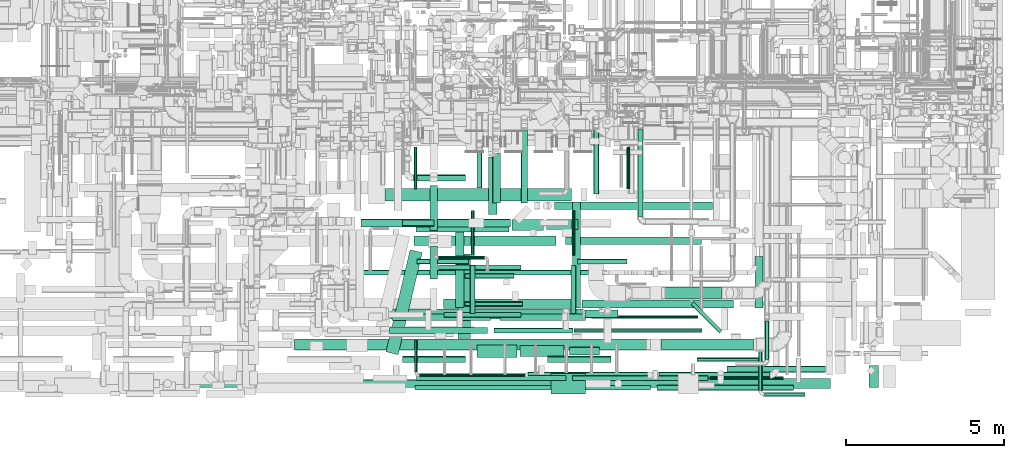
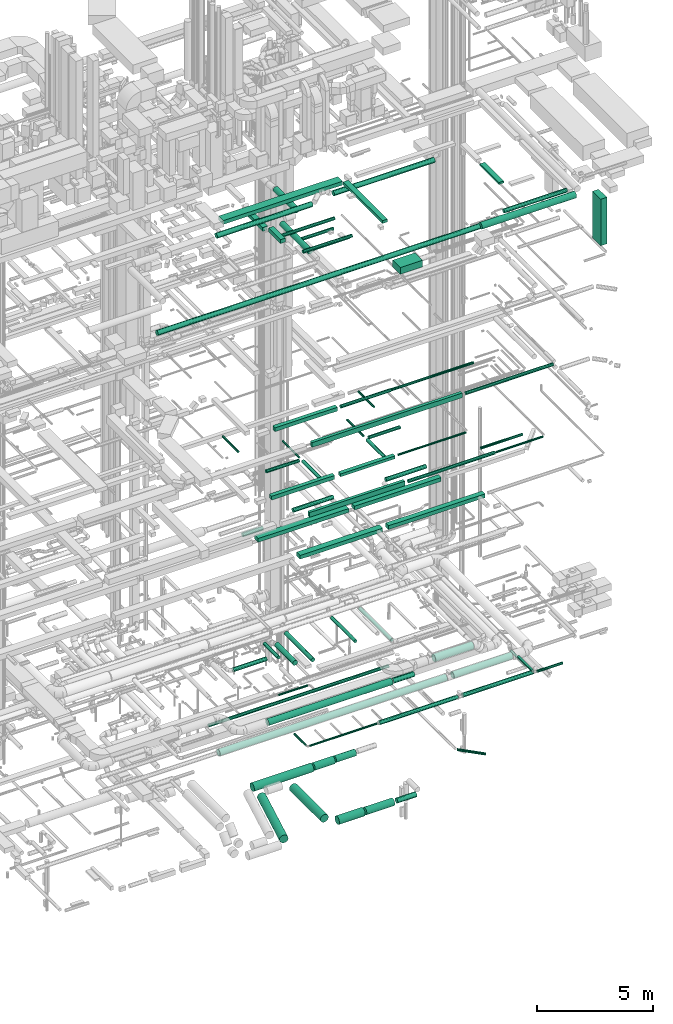
# One storey, part 49 of 337: 74 flow segments.
"""IFC2X3 building model written with IfcOpenShell, lengths in millimetres."""

from ifc_helpers import new_model, entity, si_unit, converted_unit, derived_unit, direction, frame, origin, origin_2d_with_axis, place, context, subcontext, project, spatial, polyline, rectangle, circle, outline, extrude, type_object, element, save


model = new_model("IFC2X3")

# Units and contexts
model_context = context("Model", 3, precision=0.01, world=origin(), true_north=direction((6.12303176911189e-17, 1.0)))
body_context = subcontext(model_context, "Body", "Model", "MODEL_VIEW")
ifc_project = project(units=[si_unit("LENGTHUNIT", "METRE", prefix="MILLI"), si_unit("AREAUNIT", "SQUARE_METRE"), si_unit("VOLUMEUNIT", "CUBIC_METRE"), converted_unit("PLANEANGLEUNIT", "DEGREE", entity("IfcRatioMeasure", 0.0174532925199433), si_unit("PLANEANGLEUNIT", "RADIAN"), dimensions=[0, 0, 0, 0, 0, 0, 0]), si_unit("MASSUNIT", "GRAM", prefix="KILO"), derived_unit("MASSDENSITYUNIT", [(si_unit("MASSUNIT", "GRAM", prefix="KILO"), 1), (si_unit("LENGTHUNIT", "METRE"), -3)]), derived_unit("MOMENTOFINERTIAUNIT", [(si_unit("LENGTHUNIT", "METRE"), 4)]), si_unit("TIMEUNIT", "SECOND"), si_unit("FREQUENCYUNIT", "HERTZ"), si_unit("THERMODYNAMICTEMPERATUREUNIT", "DEGREE_CELSIUS"), derived_unit("THERMALTRANSMITTANCEUNIT", [(si_unit("MASSUNIT", "GRAM", prefix="KILO"), 1), (si_unit("THERMODYNAMICTEMPERATUREUNIT", "KELVIN"), -1), (si_unit("TIMEUNIT", "SECOND"), -3)]), derived_unit("VOLUMETRICFLOWRATEUNIT", [(si_unit("LENGTHUNIT", "METRE"), 3), (si_unit("TIMEUNIT", "SECOND"), -1)]), derived_unit("MASSFLOWRATEUNIT", [(si_unit("MASSUNIT", "GRAM", prefix="KILO"), 1), (si_unit("TIMEUNIT", "SECOND"), -1)]), derived_unit("ROTATIONALFREQUENCYUNIT", [(si_unit("TIMEUNIT", "SECOND"), -1)]), si_unit("ELECTRICCURRENTUNIT", "AMPERE"), si_unit("ELECTRICVOLTAGEUNIT", "VOLT"), si_unit("POWERUNIT", "WATT"), si_unit("FORCEUNIT", "NEWTON", prefix="KILO"), si_unit("ILLUMINANCEUNIT", "LUX"), si_unit("LUMINOUSFLUXUNIT", "LUMEN"), si_unit("LUMINOUSINTENSITYUNIT", "CANDELA"), derived_unit("USERDEFINED", [(si_unit("MASSUNIT", "GRAM", prefix="KILO"), -1), (si_unit("LENGTHUNIT", "METRE"), -2), (si_unit("TIMEUNIT", "SECOND"), 3), (si_unit("LUMINOUSFLUXUNIT", "LUMEN"), 1)]), derived_unit("LINEARVELOCITYUNIT", [(si_unit("LENGTHUNIT", "METRE"), 1), (si_unit("TIMEUNIT", "SECOND"), -1)]), si_unit("PRESSUREUNIT", "PASCAL"), derived_unit("USERDEFINED", [(si_unit("LENGTHUNIT", "METRE"), -2), (si_unit("MASSUNIT", "GRAM", prefix="KILO"), 1), (si_unit("TIMEUNIT", "SECOND"), -2)]), derived_unit("LINEARFORCEUNIT", [(si_unit("MASSUNIT", "GRAM", prefix="KILO"), 1), (si_unit("LENGTHUNIT", "METRE"), 1), (si_unit("TIMEUNIT", "SECOND"), -2), (si_unit("LENGTHUNIT", "METRE"), -1)]), derived_unit("PLANARFORCEUNIT", [(si_unit("MASSUNIT", "GRAM", prefix="KILO"), 1), (si_unit("LENGTHUNIT", "METRE"), 1), (si_unit("TIMEUNIT", "SECOND"), -2), (si_unit("LENGTHUNIT", "METRE"), -2)])], contexts=[model_context])

# Site, building, storey
site_placement = place(None, origin())
site = spatial("IfcSite", under=ifc_project, at=site_placement, CompositionType="ELEMENT")
building_placement = place(site_placement, origin())
building = spatial("IfcBuilding", under=site, at=building_placement, CompositionType="ELEMENT")
storey_placement = place(building_placement, origin())
storey = spatial("IfcBuildingStorey", under=building, at=storey_placement, CompositionType="ELEMENT", Elevation=0.0)

# Flow segments
duct_segment_type_1 = type_object("IfcDuctSegmentType", PredefinedType="NOTDEFINED")
flow_segment_1_placement = place(storey_placement, frame((54557.3, 4970.54, 11300.0)))
element("IfcFlowSegment", 1, at=flow_segment_1_placement, inside=storey, type_object=duct_segment_type_1, context=body_context, shape_type="SweptSolid", body=[
    extrude(rectangle(XDim=4500.00000000001, YDim=300.0, at=origin_2d_with_axis()), frame((2250.0, 150.0, 0.0)), (0.0, 0.0, 1.0), 199.999999999998),
])
flow_segment_2_placement = place(storey_placement, frame((59357.3, 4995.54, 11300.0)))
element("IfcFlowSegment", 2, at=flow_segment_2_placement, inside=storey, type_object=duct_segment_type_1, context=body_context, shape_type="SweptSolid", body=[
    extrude(rectangle(XDim=4300.00000000001, YDim=249.999999999999, at=origin_2d_with_axis()), frame((2150.0, 125.0, 0.0)), (0.0, 0.0, 1.0), 200.000000000002),
])
flow_segment_3_placement = place(storey_placement, frame((55481.92, 2972.88, 11300.0)))
element("IfcFlowSegment", 3, at=flow_segment_3_placement, inside=storey, type_object=duct_segment_type_1, context=body_context, shape_type="SweptSolid", body=[
    extrude(rectangle(XDim=4100.00000000001, YDim=300.0, at=origin_2d_with_axis()), frame((2050.0, 150.0, 0.0)), (0.0, 0.0, 1.0), 199.999999999998),
])
flow_segment_4_placement = place(storey_placement, frame((59881.92, 2997.88, 11300.0)))
element("IfcFlowSegment", 4, at=flow_segment_4_placement, inside=storey, type_object=duct_segment_type_1, context=body_context, shape_type="SweptSolid", body=[
    extrude(rectangle(XDim=4799.99999999995, YDim=250.0, at=origin_2d_with_axis()), frame((2400.0, 125.0, 0.0)), (0.0, 0.0, 1.0), 200.000000000002),
])
flow_segment_5_placement = place(storey_placement, frame((53785.22, 2177.06, 19075.0)))
element("IfcFlowSegment", 5, at=flow_segment_5_placement, inside=storey, type_object=duct_segment_type_1, context=body_context, shape_type="SweptSolid", body=[
    extrude(rectangle(XDim=3099.99999999995, YDim=200.0, at=origin_2d_with_axis()), frame((1550.0, 100.0, 0.0)), (0.0, 0.0, 1.0), 200.000000000002),
])
flow_segment_6_placement = place(storey_placement, frame((54587.23, 388.31, 19050.0)))
element("IfcFlowSegment", 6, at=flow_segment_6_placement, inside=storey, type_object=duct_segment_type_1, context=body_context, shape_type="SweptSolid", body=[
    extrude(rectangle(XDim=7459.99999999995, YDim=150.0, at=origin_2d_with_axis()), frame((3730.0, 75.0, 0.0)), (0.0, 0.0, 1.0), 249.999999999999),
])
flow_segment_7_placement = place(storey_placement, frame((53861.01, 2600.44, 15200.0)))
element("IfcFlowSegment", 7, at=flow_segment_7_placement, inside=storey, type_object=duct_segment_type_1, context=body_context, shape_type="SweptSolid", body=[
    extrude(rectangle(XDim=3120.00000000006, YDim=200.0, at=origin_2d_with_axis()), frame((1560.0, 100.0, 0.0)), (0.0, 0.0, 1.0), 199.999999999998),
])
flow_segment_8_placement = place(storey_placement, frame((57281.01, 2600.44, 15225.0)))
element("IfcFlowSegment", 8, at=flow_segment_8_placement, inside=storey, type_object=duct_segment_type_1, context=body_context, shape_type="SweptSolid", body=[
    extrude(rectangle(XDim=2699.99999999995, YDim=200.0, at=origin_2d_with_axis()), frame((1350.0, 100.0, 0.0)), (0.0, 0.0, 1.0), 150.000000000001),
])
flow_segment_9_placement = place(storey_placement, frame((54639.29, 695.66, 15175.0)))
element("IfcFlowSegment", 9, at=flow_segment_9_placement, inside=storey, type_object=duct_segment_type_1, context=body_context, shape_type="SweptSolid", body=[
    extrude(rectangle(XDim=4729.15029264255, YDim=150.0, at=origin_2d_with_axis()), frame((2364.58, 75.0, 0.0)), (0.0, 0.0, 1.0), 249.999999999999),
])
flow_segment_10_placement = place(storey_placement, frame((53635.82, 6380.41, 27450.0)))
element("IfcFlowSegment", 10, at=flow_segment_10_placement, inside=storey, type_object=duct_segment_type_1, context=body_context, shape_type="SweptSolid", body=[
    extrude(rectangle(XDim=5913.75000000002, YDim=400.0, at=origin_2d_with_axis()), frame((2956.88, 200.0, 0.0), z_axis=(0.0, 0.0, 1.0), x_axis=(-1.0, 0.0, 0.0)), (0.0, 0.0, 1.0), 199.999999999998),
])
flow_segment_11_placement = place(storey_placement, frame((59574.57, 2987.91, 27475.0)))
element("IfcFlowSegment", 11, at=flow_segment_11_placement, inside=storey, type_object=duct_segment_type_1, context=body_context, shape_type="SweptSolid", body=[
    extrude(rectangle(XDim=3367.49999999998, YDim=250.000000000004, at=origin_2d_with_axis()), frame((125.0, 1683.75, 0.0), z_axis=(0.0, 0.0, 1.0), x_axis=(0.0, 1.0, 0.0)), (0.0, 0.0, 1.0), 150.000000000001),
])
flow_segment_12_placement = place(storey_placement, frame((65354.57, 2987.91, 27500.0)))
element("IfcFlowSegment", 12, at=flow_segment_12_placement, inside=storey, type_object=duct_segment_type_1, context=body_context, shape_type="SweptSolid", body=[
    extrude(rectangle(XDim=1636.24999999996, YDim=250.000000000004, at=origin_2d_with_axis()), frame((125.0, 818.12, 0.0), z_axis=(0.0, 0.0, 1.0), x_axis=(0.0, -1.0, 0.0)), (0.0, 0.0, 1.0), 100.000000000003),
])
flow_segment_13_placement = place(storey_placement, frame((68968.15, 473.12, 24545.0)))
element("IfcFlowSegment", 13, at=flow_segment_13_placement, inside=storey, type_object=duct_segment_type_1, context=body_context, shape_type="SweptSolid", body=[
    extrude(rectangle(XDim=700.0, YDim=300.000000000001, at=origin_2d_with_axis()), frame((150.0, 350.0, 0.0), z_axis=(0.0, 0.0, 1.0), x_axis=(0.0, -1.0, 0.0)), (0.0, 0.0, 1.0), 2440.00000000001),
])
flow_segment_14_placement = place(storey_placement, frame((55054.59, 5448.41, 27150.0)))
element("IfcFlowSegment", 14, at=flow_segment_14_placement, inside=storey, type_object=duct_segment_type_1, context=body_context, shape_type="SweptSolid", body=[
    extrude(rectangle(XDim=1430.81282899736, YDim=250.000000000004, at=origin_2d_with_axis()), frame((125.0, 715.41, 0.0), z_axis=(0.0, 0.0, 1.0), x_axis=(0.0, -1.0, 0.0)), (0.0, 0.0, 1.0), 199.999999999998),
])
flow_segment_15_placement = place(storey_placement, frame((55054.59, 3912.24, 27450.0)))
element("IfcFlowSegment", 15, at=flow_segment_15_placement, inside=storey, type_object=duct_segment_type_1, context=body_context, shape_type="SweptSolid", body=[
    extrude(rectangle(XDim=1029.05982822021, YDim=250.000000000004, at=origin_2d_with_axis()), frame((125.0, 514.53, 0.0), z_axis=(0.0, 0.0, 1.0), x_axis=(0.0, 1.0, 0.0)), (0.0, 0.0, 1.0), 199.999999999998),
])
flow_segment_16_placement = place(storey_placement, frame((58894.8, 268.17, 26700.0)))
element("IfcFlowSegment", 16, at=flow_segment_16_placement, inside=storey, type_object=duct_segment_type_1, context=body_context, shape_type="SweptSolid", body=[
    extrude(rectangle(XDim=1100.0, YDim=650.0, at=origin_2d_with_axis()), frame((550.0, 325.0, 0.0)), (0.0, 0.0, 1.0), 349.999999999998),
])
duct_segment_type_2 = type_object("IfcDuctSegmentType", PredefinedType="NOTDEFINED")
flow_segment_17_placement = place(storey_placement, frame((54616.92, 5397.13, -2151.6)))
element("IfcFlowSegment", 17, at=flow_segment_17_placement, inside=storey, type_object=duct_segment_type_2, context=body_context, shape_type="SweptSolid", body=[
    extrude(circle(Radius=200.0, at=origin_2d_with_axis()), frame((0.0, 201.6, 201.6), z_axis=(1.0, 0.0, 0.0), x_axis=(0.0, -1.0, 0.0)), (0.0, 0.0, 1.0), 2951.06360611809),
])
flow_segment_18_placement = place(storey_placement, frame((57659.98, 5441.63, -2129.1)))
element("IfcFlowSegment", 18, at=flow_segment_18_placement, inside=storey, type_object=duct_segment_type_2, context=body_context, shape_type="SweptSolid", body=[
    extrude(circle(Radius=177.5, at=origin_2d_with_axis()), frame((0.0, 179.1, 179.1), z_axis=(1.0, 0.0, 0.0), x_axis=(0.0, -1.0, 0.0)), (0.0, 0.0, 1.0), 999.633099706871),
])
flow_segment_19_placement = place(storey_placement, frame((58744.62, 5482.13, -2109.1)))
element("IfcFlowSegment", 19, at=flow_segment_19_placement, inside=storey, type_object=duct_segment_type_2, context=body_context, shape_type="SweptSolid", body=[
    extrude(circle(Radius=157.5, at=origin_2d_with_axis()), frame((0.0, 159.1, 159.1), z_axis=(1.0, 0.0, 0.0), x_axis=(0.0, -1.0, 0.0)), (0.0, 0.0, 1.0), 999.769934937476),
])
flow_segment_20_placement = place(storey_placement, frame((53661.77, 1508.85, -2151.6)))
element("IfcFlowSegment", 20, at=flow_segment_20_placement, inside=storey, type_object=duct_segment_type_2, context=body_context, shape_type="SweptSolid", body=[
    extrude(circle(Radius=200.0, at=origin_2d_with_axis()), frame((196.21, 47.69, 201.6), z_axis=(0.230466228592691, 0.973080324268383, 0.0), x_axis=(-0.973080324268383, 0.230466228592691, 0.0)), (0.0, 0.0, 1.0), 3323.43288947381),
])
flow_segment_21_placement = place(storey_placement, frame((55942.39, 2026.52, -2151.6)))
element("IfcFlowSegment", 21, at=flow_segment_21_placement, inside=storey, type_object=duct_segment_type_2, context=body_context, shape_type="SweptSolid", body=[
    extrude(circle(Radius=200.0, at=origin_2d_with_axis()), frame((201.6, 0.0, 201.6), z_axis=(0.0, 1.0, 0.0), x_axis=(-1.0, 0.0, 0.0)), (0.0, 0.0, 1.0), 2671.80245293195),
])
flow_segment_22_placement = place(storey_placement, frame((59484.61, 1499.92, -2076.6)))
element("IfcFlowSegment", 22, at=flow_segment_22_placement, inside=storey, type_object=duct_segment_type_2, context=body_context, shape_type="SweptSolid", body=[
    extrude(circle(Radius=125.0, at=origin_2d_with_axis()), frame((0.0, 126.6, 126.6), z_axis=(1.0, 0.0, 0.0), x_axis=(0.0, -1.0, 0.0)), (0.0, 0.0, 1.0), 954.521669775234),
])
flow_segment_23_placement = place(storey_placement, frame((56543.98, 1424.92, -2151.6)))
element("IfcFlowSegment", 23, at=flow_segment_23_placement, inside=storey, type_object=duct_segment_type_2, context=body_context, shape_type="SweptSolid", body=[
    extrude(circle(Radius=200.0, at=origin_2d_with_axis()), frame((0.0, 201.6, 201.6), z_axis=(1.0, 0.0, 0.0), x_axis=(0.0, -1.0, 0.0)), (0.0, 0.0, 1.0), 1280.36323550003),
])
flow_segment_24_placement = place(storey_placement, frame((57916.35, 1447.42, -2129.1)))
element("IfcFlowSegment", 24, at=flow_segment_24_placement, inside=storey, type_object=duct_segment_type_2, context=body_context, shape_type="SweptSolid", body=[
    extrude(circle(Radius=177.5, at=origin_2d_with_axis()), frame((0.0, 179.1, 179.1), z_axis=(1.0, 0.0, 0.0), x_axis=(0.0, -1.0, 0.0)), (0.0, 0.0, 1.0), 1394.26236472474),
])
flow_segment_25_placement = place(storey_placement, frame((63328.93, 2191.65, -1614.1)))
element("IfcFlowSegment", 25, at=flow_segment_25_placement, inside=storey, type_object=duct_segment_type_2, context=body_context, shape_type="SweptSolid", body=[
    extrude(circle(Radius=62.5, at=origin_2d_with_axis()), frame((946.44, 45.79, 64.1), z_axis=(-0.707106781186597, 0.707106781186498, 0.0), x_axis=(-0.707106781186498, -0.707106781186597, 0.0)), (0.0, 0.0, 1.0), 1273.71806347082),
])
flow_segment_26_placement = place(storey_placement, frame((54181.92, 5578.95, 11298.4)))
element("IfcFlowSegment", 26, at=flow_segment_26_placement, inside=storey, type_object=duct_segment_type_2, context=body_context, shape_type="SweptSolid", body=[
    extrude(circle(Radius=100.0, at=origin_2d_with_axis()), frame((0.0, 101.6, 101.6), z_axis=(1.0, 0.0, 0.0), x_axis=(0.0, -1.0, 0.0)), (0.0, 0.0, 1.0), 999.99999999992),
])
flow_segment_27_placement = place(storey_placement, frame((53750.84, 2644.65, 3290.9)))
element("IfcFlowSegment", 27, at=flow_segment_27_placement, inside=storey, type_object=duct_segment_type_2, context=body_context, shape_type="SweptSolid", body=[
    extrude(circle(Radius=157.5, at=origin_2d_with_axis()), frame((0.0, 159.1, 159.1), z_axis=(1.0, 0.0, 0.0), x_axis=(0.0, -1.0, 0.0)), (0.0, 0.0, 1.0), 6152.38970540996),
])
flow_segment_28_placement = place(storey_placement, frame((59968.23, 2677.15, 3323.4)))
element("IfcFlowSegment", 28, at=flow_segment_28_placement, inside=storey, type_object=duct_segment_type_2, context=body_context, shape_type="SweptSolid", body=[
    extrude(circle(Radius=125.0, at=origin_2d_with_axis()), frame((0.0, 126.6, 126.6), z_axis=(1.0, 0.0, 0.0), x_axis=(0.0, -1.0, 0.0)), (0.0, 0.0, 1.0), 1044.99999999996),
])
flow_segment_29_placement = place(storey_placement, frame((61645.81, 5891.17, 3018.4)))
element("IfcFlowSegment", 29, at=flow_segment_29_placement, inside=storey, type_object=duct_segment_type_2, context=body_context, shape_type="SweptSolid", body=[
    extrude(outline(polyline([(-10.44, -79.32), (10.44, -79.32), (30.61, -73.91), (48.7, -63.47), (63.47, -48.7), (73.91, -30.61), (79.32, -10.44), (79.32, 10.44), (73.91, 30.61), (63.47, 48.7), (48.7, 63.47), (30.61, 73.91), (10.44, 79.32), (-10.44, 79.32), (-30.61, 73.91), (-48.7, 63.47), (-63.47, 48.7), (-73.91, 30.61), (-79.32, 10.44), (-79.32, -10.44), (-73.91, -30.61), (-63.47, -48.7), (-48.7, -63.47), (-30.61, -73.91), (-10.44, -79.32)])), frame((81.6, 0.0, 81.6), z_axis=(8.3440502931814e-09, 1.0, 0.0), x_axis=(0.130526192220055, -1.08913121497131e-09, 0.99144486137381)), (0.0, 0.0, 1.0), 2751.21031061176),
])
flow_segment_30_placement = place(storey_placement, frame((65670.58, 1352.18, 3075.9)))
element("IfcFlowSegment", 30, at=flow_segment_30_placement, inside=storey, type_object=duct_segment_type_2, context=body_context, shape_type="SweptSolid", body=[
    extrude(circle(Radius=62.5, at=origin_2d_with_axis()), frame((64.1, 0.0, 64.1), z_axis=(0.0, 1.0, 0.0), x_axis=(-1.0, 0.0, 0.0)), (0.0, 0.0, 1.0), 1230.00000000002),
])
flow_segment_31_placement = place(storey_placement, frame((62247.23, 381.72, 19093.4)))
element("IfcFlowSegment", 31, at=flow_segment_31_placement, inside=storey, type_object=duct_segment_type_2, context=body_context, shape_type="SweptSolid", body=[
    extrude(circle(Radius=80.0, at=origin_2d_with_axis()), frame((0.0, 81.6, 81.6), z_axis=(1.0, 0.0, 0.0), x_axis=(0.0, -1.0, 0.0)), (0.0, 0.0, 1.0), 4336.87499999998),
])
flow_segment_32_placement = place(storey_placement, frame((56332.36, 2820.44, 15218.4)))
element("IfcFlowSegment", 32, at=flow_segment_32_placement, inside=storey, type_object=duct_segment_type_2, context=body_context, shape_type="SweptSolid", body=[
    extrude(circle(Radius=80.0, at=origin_2d_with_axis()), frame((81.6, 0.0, 81.6), z_axis=(-3.39017242221054e-07, 1.0, 0.0), x_axis=(-1.0, -3.39017242221054e-07, 0.0)), (0.0, 0.0, 1.0), 1511.64807287868),
])
flow_segment_33_placement = place(storey_placement, frame((56362.36, 4652.09, 15248.4)))
element("IfcFlowSegment", 33, at=flow_segment_33_placement, inside=storey, type_object=duct_segment_type_2, context=body_context, shape_type="SweptSolid", body=[
    extrude(circle(Radius=50.0, at=origin_2d_with_axis()), frame((51.6, 0.0, 51.6), z_axis=(0.0, 1.0, 0.0), x_axis=(1.0, 0.0, 0.0)), (0.0, 0.0, 1.0), 1420.0),
])
flow_segment_34_placement = place(storey_placement, frame((54643.95, 4380.5, 15218.4)))
element("IfcFlowSegment", 34, at=flow_segment_34_placement, inside=storey, type_object=duct_segment_type_2, context=body_context, shape_type="SweptSolid", body=[
    extrude(circle(Radius=80.0, at=origin_2d_with_axis()), frame((0.0, 81.6, 81.6), z_axis=(1.0, 0.0, 0.0), x_axis=(0.0, 1.0, 0.0)), (0.0, 0.0, 1.0), 1639.9995451582),
])
flow_segment_35_placement = place(storey_placement, frame((59526.85, 2820.44, 15218.4)))
element("IfcFlowSegment", 35, at=flow_segment_35_placement, inside=storey, type_object=duct_segment_type_2, context=body_context, shape_type="SweptSolid", body=[
    extrude(circle(Radius=80.0, at=origin_2d_with_axis()), frame((81.6, 0.0, 81.6), z_axis=(-3.39017242221043e-07, 1.0, 0.0), x_axis=(-1.0, -3.39017242221043e-07, 0.0)), (0.0, 0.0, 1.0), 1511.64807287874),
])
flow_segment_36_placement = place(storey_placement, frame((59556.85, 4652.09, 15248.4)))
element("IfcFlowSegment", 36, at=flow_segment_36_placement, inside=storey, type_object=duct_segment_type_2, context=body_context, shape_type="SweptSolid", body=[
    extrude(circle(Radius=50.0, at=origin_2d_with_axis()), frame((51.6, 0.0, 51.6), z_axis=(0.0, 1.0, 0.0), x_axis=(1.0, 0.0, 0.0)), (0.0, 0.0, 1.0), 1420.0),
])
flow_segment_37_placement = place(storey_placement, frame((59738.45, 4380.5, 15218.4)))
element("IfcFlowSegment", 37, at=flow_segment_37_placement, inside=storey, type_object=duct_segment_type_2, context=body_context, shape_type="SweptSolid", body=[
    extrude(circle(Radius=80.0, at=origin_2d_with_axis()), frame((0.0, 81.6, 81.6), z_axis=(1.0, 0.0, 0.0), x_axis=(0.0, -1.0, 0.0)), (0.0, 0.0, 1.0), 1560.0),
])
flow_segment_38_placement = place(storey_placement, frame((60181.01, 2648.85, 15248.4)))
element("IfcFlowSegment", 38, at=flow_segment_38_placement, inside=storey, type_object=duct_segment_type_2, context=body_context, shape_type="SweptSolid", body=[
    extrude(circle(Radius=50.0, at=origin_2d_with_axis()), frame((0.0, 51.6, 51.6), z_axis=(1.0, 0.0, 0.0), x_axis=(0.0, 1.0, 0.0)), (0.0, 0.0, 1.0), 3375.00000000001),
])
flow_segment_39_placement = place(storey_placement, frame((54190.19, 1260.8, 15198.4)))
element("IfcFlowSegment", 39, at=flow_segment_39_placement, inside=storey, type_object=duct_segment_type_2, context=body_context, shape_type="SweptSolid", body=[
    extrude(circle(Radius=100.0, at=origin_2d_with_axis()), frame((0.0, 101.6, 101.6), z_axis=(1.0, 0.0, 0.0), x_axis=(0.0, -1.0, 0.0)), (0.0, 0.0, 1.0), 2000.00000000001),
])
flow_segment_40_placement = place(storey_placement, frame((61288.96, 6759.63, 14898.4)))
element("IfcFlowSegment", 40, at=flow_segment_40_placement, inside=storey, type_object=duct_segment_type_2, context=body_context, shape_type="SweptSolid", body=[
    extrude(circle(Radius=50.0, at=origin_2d_with_axis()), frame((51.6, 0.0, 51.6), z_axis=(0.0, 1.0, 0.0), x_axis=(-1.0, 0.0, 0.0)), (0.0, 0.0, 1.0), 1340.00000000001),
])
flow_segment_41_placement = place(storey_placement, frame((54554.25, 6759.63, 14898.4)))
element("IfcFlowSegment", 41, at=flow_segment_41_placement, inside=storey, type_object=duct_segment_type_2, context=body_context, shape_type="SweptSolid", body=[
    extrude(circle(Radius=50.0, at=origin_2d_with_axis()), frame((51.6, 0.0, 51.6), z_axis=(0.0, 1.0, 0.0), x_axis=(-1.0, 0.0, 0.0)), (0.0, 0.0, 1.0), 1340.00000000008),
])
flow_segment_42_placement = place(storey_placement, frame((58790.19, 1260.8, 15198.4)))
element("IfcFlowSegment", 42, at=flow_segment_42_placement, inside=storey, type_object=duct_segment_type_2, context=body_context, shape_type="SweptSolid", body=[
    extrude(circle(Radius=100.0, at=origin_2d_with_axis()), frame((0.0, 101.6, 101.6), z_axis=(1.0, 0.0, 0.0), x_axis=(0.0, -1.0, 0.0)), (0.0, 0.0, 1.0), 2000.00000000001),
])
flow_segment_43_placement = place(storey_placement, frame((59568.45, 689.06, 15218.4)))
element("IfcFlowSegment", 43, at=flow_segment_43_placement, inside=storey, type_object=duct_segment_type_2, context=body_context, shape_type="SweptSolid", body=[
    extrude(circle(Radius=80.0, at=origin_2d_with_axis()), frame((0.0, 81.6, 81.6), z_axis=(1.0, 0.0, 0.0), x_axis=(0.0, -1.0, 0.0)), (0.0, 0.0, 1.0), 4300.0),
])
flow_segment_44_placement = place(storey_placement, frame((63515.19, 1298.3, 15235.9)))
element("IfcFlowSegment", 44, at=flow_segment_44_placement, inside=storey, type_object=duct_segment_type_2, context=body_context, shape_type="SweptSolid", body=[
    extrude(circle(Radius=62.5, at=origin_2d_with_axis()), frame((0.0, 64.1, 64.1), z_axis=(1.0, 0.0, 0.0), x_axis=(0.0, -1.0, 0.0)), (0.0, 0.0, 1.0), 2075.00000000007),
])
flow_segment_45_placement = place(storey_placement, frame((63928.45, 719.06, 15248.4)))
element("IfcFlowSegment", 45, at=flow_segment_45_placement, inside=storey, type_object=duct_segment_type_2, context=body_context, shape_type="SweptSolid", body=[
    extrude(circle(Radius=50.0, at=origin_2d_with_axis()), frame((0.0, 51.6, 51.6), z_axis=(1.0, 0.0, 0.0), x_axis=(0.0, -1.0, 0.0)), (0.0, 0.0, 1.0), 2340.00000000001),
])
flow_segment_46_placement = place(storey_placement, frame((64469.87, 948.29, 27498.4)))
element("IfcFlowSegment", 46, at=flow_segment_46_placement, inside=storey, type_object=duct_segment_type_2, context=body_context, shape_type="SweptSolid", body=[
    extrude(circle(Radius=100.0, at=origin_2d_with_axis()), frame((0.0, 101.6, 101.6), z_axis=(1.0, 0.0, 0.0), x_axis=(0.0, 1.0, 0.0)), (0.0, 0.0, 1.0), 3126.86241545841),
])
flow_segment_47_placement = place(storey_placement, frame((55504.59, 2694.37, 27468.4)))
element("IfcFlowSegment", 47, at=flow_segment_47_placement, inside=storey, type_object=duct_segment_type_2, context=body_context, shape_type="SweptSolid", body=[
    extrude(circle(Radius=80.0, at=origin_2d_with_axis()), frame((0.0, 81.6, 81.6), z_axis=(1.0, 0.0, 0.0), x_axis=(0.0, -1.0, 0.0)), (0.0, 0.0, 1.0), 2434.58382599763),
])
flow_segment_48_placement = place(storey_placement, frame((55324.59, 4195.65, 27468.4)))
element("IfcFlowSegment", 48, at=flow_segment_48_placement, inside=storey, type_object=duct_segment_type_2, context=body_context, shape_type="SweptSolid", body=[
    extrude(circle(Radius=80.0, at=origin_2d_with_axis()), frame((0.0, 81.6, 81.6), z_axis=(1.0, 0.0, 0.0), x_axis=(0.0, -1.0, 0.0)), (0.0, 0.0, 1.0), 2616.24999999989),
])
flow_segment_49_placement = place(storey_placement, frame((55863.34, 3003.11, 27118.4)))
element("IfcFlowSegment", 49, at=flow_segment_49_placement, inside=storey, type_object=duct_segment_type_2, context=body_context, shape_type="SweptSolid", body=[
    extrude(circle(Radius=140.0, at=origin_2d_with_axis()), frame((141.6, 0.0, 141.6), z_axis=(0.0, 1.0, 0.0), x_axis=(1.0, 0.0, 0.0)), (0.0, 0.0, 1.0), 2397.49999999999),
])
flow_segment_50_placement = place(storey_placement, frame((56164.62, 3916.72, 27168.4)))
element("IfcFlowSegment", 50, at=flow_segment_50_placement, inside=storey, type_object=duct_segment_type_2, context=body_context, shape_type="SweptSolid", body=[
    extrude(circle(Radius=80.0, at=origin_2d_with_axis()), frame((0.0, 81.6, 81.6), z_axis=(1.0, 0.0, 0.0), x_axis=(0.0, -1.0, 0.0)), (0.0, 0.0, 1.0), 1560.31470495926),
])
flow_segment_51_placement = place(storey_placement, frame((56164.62, 3032.64, 27168.4)))
element("IfcFlowSegment", 51, at=flow_segment_51_placement, inside=storey, type_object=duct_segment_type_2, context=body_context, shape_type="SweptSolid", body=[
    extrude(circle(Radius=80.0, at=origin_2d_with_axis()), frame((0.0, 81.6, 81.6), z_axis=(1.0, 0.0, 0.0), x_axis=(0.0, -1.0, 0.0)), (0.0, 0.0, 1.0), 1820.31470495927),
])
flow_segment_52_placement = place(storey_placement, frame((63062.74, 434.08, 27430.9)))
element("IfcFlowSegment", 52, at=flow_segment_52_placement, inside=storey, type_object=duct_segment_type_2, context=body_context, shape_type="SweptSolid", body=[
    extrude(circle(Radius=157.5, at=origin_2d_with_axis()), frame((0.0, 159.1, 159.1), z_axis=(1.0, 0.0, 0.0), x_axis=(0.0, 1.0, 0.0)), (0.0, 0.0, 1.0), 4685.00000000001),
])
flow_segment_53_placement = place(storey_placement, frame((46997.3, 466.58, 27463.4)))
element("IfcFlowSegment", 53, at=flow_segment_53_placement, inside=storey, type_object=duct_segment_type_2, context=body_context, shape_type="SweptSolid", body=[
    extrude(circle(Radius=125.0, at=origin_2d_with_axis()), frame((0.0, 126.6, 126.6), z_axis=(1.0, 0.0, 0.0), x_axis=(0.0, 1.0, 0.0)), (0.0, 0.0, 1.0), 16000.4434048333),
])
flow_segment_54_placement = place(storey_placement, frame((60247.19, 6607.6, 3018.4)))
element("IfcFlowSegment", 54, at=flow_segment_54_placement, inside=storey, type_object=duct_segment_type_2, context=body_context, shape_type="SweptSolid", body=[
    extrude(outline(polyline([(-10.44, -79.32), (10.44, -79.32), (30.61, -73.91), (48.7, -63.47), (63.47, -48.7), (73.91, -30.61), (79.32, -10.44), (79.32, 10.44), (73.91, 30.61), (63.47, 48.7), (48.7, 63.47), (30.61, 73.91), (10.44, 79.32), (-10.44, 79.32), (-30.61, 73.91), (-48.7, 63.47), (-63.47, 48.7), (-73.91, 30.61), (-79.32, 10.44), (-79.32, -10.44), (-73.91, -30.61), (-63.47, -48.7), (-48.7, -63.47), (-30.61, -73.91), (-10.44, -79.32)])), frame((81.6, 0.0, 81.6), z_axis=(0.0, 1.0, 0.0), x_axis=(0.130526192220055, 0.0, 0.99144486137381)), (0.0, 0.0, 1.0), 2033.72583002032),
])
flow_segment_55_placement = place(storey_placement, frame((59003.03, 6103.9, 27174.04)))
element("IfcFlowSegment", 55, at=flow_segment_55_placement, inside=storey, type_object=duct_segment_type_2, context=body_context, shape_type="SweptSolid", body=[
    extrude(circle(Radius=125.0, at=origin_2d_with_axis()), frame((0.0, 125.96, 125.96), z_axis=(1.0, 0.0, 0.0), x_axis=(0.0, 0.584613414413232, 0.811311996514351)), (0.0, 0.0, 1.0), 5003.41101318828),
])
flow_segment_56_placement = place(storey_placement, frame((52877.39, 5553.69, 27423.4)))
element("IfcFlowSegment", 56, at=flow_segment_56_placement, inside=storey, type_object=duct_segment_type_2, context=body_context, shape_type="SweptSolid", body=[
    extrude(circle(Radius=125.0, at=origin_2d_with_axis()), frame((0.0, 126.6, 126.6), z_axis=(1.0, 0.0, 0.0), x_axis=(0.0, 1.0, 0.0)), (0.0, 0.0, 1.0), 4741.44660940679),
])
flow_segment_57_placement = place(storey_placement, frame((57948.72, 6311.05, 2998.4)))
element("IfcFlowSegment", 57, at=flow_segment_57_placement, inside=storey, type_object=duct_segment_type_2, context=body_context, shape_type="SweptSolid", body=[
    extrude(circle(Radius=100.0, at=origin_2d_with_axis()), frame((101.6, 0.0, 101.6), z_axis=(0.0, 1.0, 0.0), x_axis=(-1.0, 0.0, 0.0)), (0.0, 0.0, 1.0), 2317.24508060277),
])
flow_segment_58_placement = place(storey_placement, frame((54531.91, 7011.47, 3218.4)))
element("IfcFlowSegment", 58, at=flow_segment_58_placement, inside=storey, type_object=duct_segment_type_2, context=body_context, shape_type="SweptSolid", body=[
    extrude(circle(Radius=100.0, at=origin_2d_with_axis()), frame((0.0, 101.6, 101.6), z_axis=(1.0, 0.0, 0.0), x_axis=(0.0, -1.0, 0.0)), (0.0, 0.0, 1.0), 1660.20000000001),
])
flow_segment_59_placement = place(storey_placement, frame((56541.69, 6788.91, 3348.4)))
element("IfcFlowSegment", 59, at=flow_segment_59_placement, inside=storey, type_object=duct_segment_type_2, context=body_context, shape_type="SweptSolid", body=[
    extrude(circle(Radius=80.0, at=origin_2d_with_axis()), frame((81.6, 0.0, 81.6), z_axis=(5.06496820018117e-08, 1.0, 0.0), x_axis=(1.0, -5.06496820018117e-08, 0.0)), (0.0, 0.0, 1.0), 1211.27416997973),
])
flow_segment_60_placement = place(storey_placement, frame((54721.73, 810.59, 2998.4)))
element("IfcFlowSegment", 60, at=flow_segment_60_placement, inside=storey, type_object=duct_segment_type_2, context=body_context, shape_type="SweptSolid", body=[
    extrude(circle(Radius=50.0, at=origin_2d_with_axis()), frame((0.0, 51.6, 51.6), z_axis=(1.0, 0.0, 0.0), x_axis=(0.0, -1.0, 0.0)), (0.0, 0.0, 1.0), 3350.77104855534),
])
flow_segment_61_placement = place(storey_placement, frame((50763.55, 1670.27, 3340.9)))
element("IfcFlowSegment", 61, at=flow_segment_61_placement, inside=storey, type_object=duct_segment_type_2, context=body_context, shape_type="SweptSolid", body=[
    extrude(circle(Radius=157.5, at=origin_2d_with_axis()), frame((0.0, 159.1, 159.1), z_axis=(1.0, 0.0, 0.0), x_axis=(0.0, 1.0, 0.0)), (0.0, 0.0, 1.0), 11283.9478056898),
])
flow_segment_62_placement = place(storey_placement, frame((65471.87, 379.37, 3435.9)))
element("IfcFlowSegment", 62, at=flow_segment_62_placement, inside=storey, type_object=duct_segment_type_2, context=body_context, shape_type="SweptSolid", body=[
    extrude(circle(Radius=62.5, at=origin_2d_with_axis()), frame((64.1, 0.0, 64.1), z_axis=(0.0, 1.0, 0.0), x_axis=(-1.0, 0.0, 0.0)), (0.0, 0.0, 1.0), 1230.0),
])
flow_segment_63_placement = place(storey_placement, frame((65660.97, 190.27, 3435.9)))
element("IfcFlowSegment", 63, at=flow_segment_63_placement, inside=storey, type_object=duct_segment_type_2, context=body_context, shape_type="SweptSolid", body=[
    extrude(circle(Radius=62.5, at=origin_2d_with_axis()), frame((0.0, 64.1, 64.1), z_axis=(1.0, 0.0, 0.0), x_axis=(0.0, -1.0, 0.0)), (0.0, 0.0, 1.0), 1275.00000000001),
])
flow_segment_64_placement = place(storey_placement, frame((62392.5, 3285.06, 3220.9)))
element("IfcFlowSegment", 64, at=flow_segment_64_placement, inside=storey, type_object=duct_segment_type_2, context=body_context, shape_type="SweptSolid", body=[
    extrude(circle(Radius=177.5, at=origin_2d_with_axis()), frame((0.0, 179.1, 179.1), z_axis=(1.0, 0.0, 0.0), x_axis=(0.0, -1.0, 0.0)), (0.0, 0.0, 1.0), 1915.90430928514),
])
flow_segment_65_placement = place(storey_placement, frame((57043.49, 6311.05, 3123.4)))
element("IfcFlowSegment", 65, at=flow_segment_65_placement, inside=storey, type_object=duct_segment_type_2, context=body_context, shape_type="SweptSolid", body=[
    extrude(circle(Radius=125.0, at=origin_2d_with_axis()), frame((126.6, 0.0, 126.6), z_axis=(0.0, 1.0, 0.0), x_axis=(1.0, 0.0, 0.0)), (0.0, 0.0, 1.0), 1573.29698218554),
])
flow_segment_66_placement = place(storey_placement, frame((54570.13, 962.18, 2998.4)))
element("IfcFlowSegment", 66, at=flow_segment_66_placement, inside=storey, type_object=duct_segment_type_2, context=body_context, shape_type="SweptSolid", body=[
    extrude(circle(Radius=50.0, at=origin_2d_with_axis()), frame((51.6, 0.0, 51.6), z_axis=(0.0, 1.0, 0.0), x_axis=(1.0, 0.0, 0.0)), (0.0, 0.0, 1.0), 1000.0000000001),
])
flow_segment_67_placement = place(storey_placement, frame((62372.5, 1670.27, 3340.9)))
element("IfcFlowSegment", 67, at=flow_segment_67_placement, inside=storey, type_object=duct_segment_type_2, context=body_context, shape_type="SweptSolid", body=[
    extrude(circle(Radius=157.5, at=origin_2d_with_axis()), frame((0.0, 159.1, 159.1), z_axis=(1.0, 0.0, 0.0), x_axis=(0.0, 1.0, 0.0)), (0.0, 0.0, 1.0), 2941.46729274081),
])
flow_segment_68_placement = place(storey_placement, frame((62312.5, 760.59, 2948.4)))
element("IfcFlowSegment", 68, at=flow_segment_68_placement, inside=storey, type_object=duct_segment_type_2, context=body_context, shape_type="SweptSolid", body=[
    extrude(circle(Radius=100.0, at=origin_2d_with_axis()), frame((0.0, 101.6, 101.6), z_axis=(1.0, 0.0, 0.0), x_axis=(0.0, 1.0, 0.0)), (0.0, 0.0, 1.0), 3516.85905299235),
])
flow_segment_69_placement = place(storey_placement, frame((51585.0, 4028.69, 3168.4)))
element("IfcFlowSegment", 69, at=flow_segment_69_placement, inside=storey, type_object=duct_segment_type_2, context=body_context, shape_type="SweptSolid", body=[
    extrude(circle(Radius=80.0, at=origin_2d_with_axis()), frame((0.0, 81.6, 81.6), z_axis=(1.0, 0.0, 0.0), x_axis=(0.0, 1.0, 0.0)), (0.0, 0.0, 1.0), 8939.99999999999),
])
flow_segment_70_placement = place(storey_placement, frame((58172.5, 760.59, 2948.4)))
element("IfcFlowSegment", 70, at=flow_segment_70_placement, inside=storey, type_object=duct_segment_type_2, context=body_context, shape_type="SweptSolid", body=[
    extrude(circle(Radius=100.0, at=origin_2d_with_axis()), frame((0.0, 101.6, 101.6), z_axis=(1.0, 0.0, 0.0), x_axis=(0.0, 1.0, 0.0)), (0.0, 0.0, 1.0), 3905.00000000001),
])
flow_segment_71_placement = place(storey_placement, frame((55325.06, 4528.69, 3198.4)))
element("IfcFlowSegment", 71, at=flow_segment_71_placement, inside=storey, type_object=duct_segment_type_2, context=body_context, shape_type="SweptSolid", body=[
    extrude(circle(Radius=50.0, at=origin_2d_with_axis()), frame((0.0, 51.6, 51.6), z_axis=(1.0, 0.0, 0.0), x_axis=(0.0, 1.0, 0.0)), (0.0, 0.0, 1.0), 1460.00000000001),
])
flow_segment_72_placement = place(storey_placement, frame((56909.56, 5960.61, 27118.4)))
element("IfcFlowSegment", 72, at=flow_segment_72_placement, inside=storey, type_object=duct_segment_type_2, context=body_context, shape_type="SweptSolid", body=[
    extrude(circle(Radius=140.0, at=origin_2d_with_axis()), frame((141.6, 0.0, 141.6), z_axis=(0.0, 1.0, 0.0), x_axis=(1.0, 0.0, 0.0)), (0.0, 0.0, 1.0), 1812.87190609998),
])
duct_segment_type_3 = type_object("IfcDuctSegmentType", PredefinedType="NOTDEFINED")
flow_segment_73_placement = place(storey_placement, frame((57085.22, 2195.47, 19093.4)))
element("IfcFlowSegment", 73, at=flow_segment_73_placement, inside=storey, type_object=duct_segment_type_3, context=body_context, shape_type="SweptSolid", body=[
    extrude(circle(Radius=80.0, at=origin_2d_with_axis()), frame((0.0, 81.6, 81.6), z_axis=(1.0, 0.0, 0.0), x_axis=(0.0, -1.0, 0.0)), (0.0, 0.0, 1.0), 2500.0),
])
flow_segment_74_placement = place(storey_placement, frame((59620.22, 2212.97, 19110.9)))
element("IfcFlowSegment", 74, at=flow_segment_74_placement, inside=storey, type_object=duct_segment_type_3, context=body_context, shape_type="SweptSolid", body=[
    extrude(circle(Radius=62.5, at=origin_2d_with_axis()), frame((0.0, 64.1, 64.1), z_axis=(1.0, 0.0, 0.0), x_axis=(0.0, -1.0, 0.0)), (0.0, 0.0, 1.0), 4064.99999999999),
])

save(model, "model.ifc")
